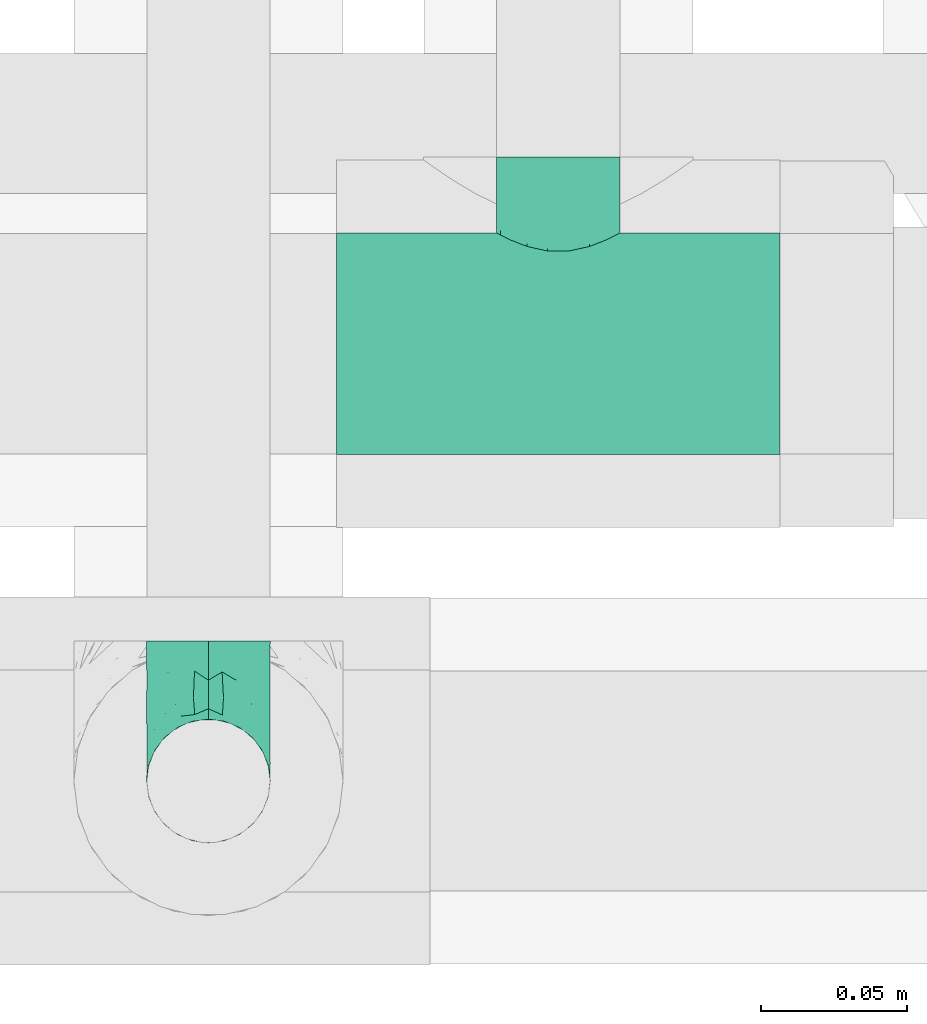
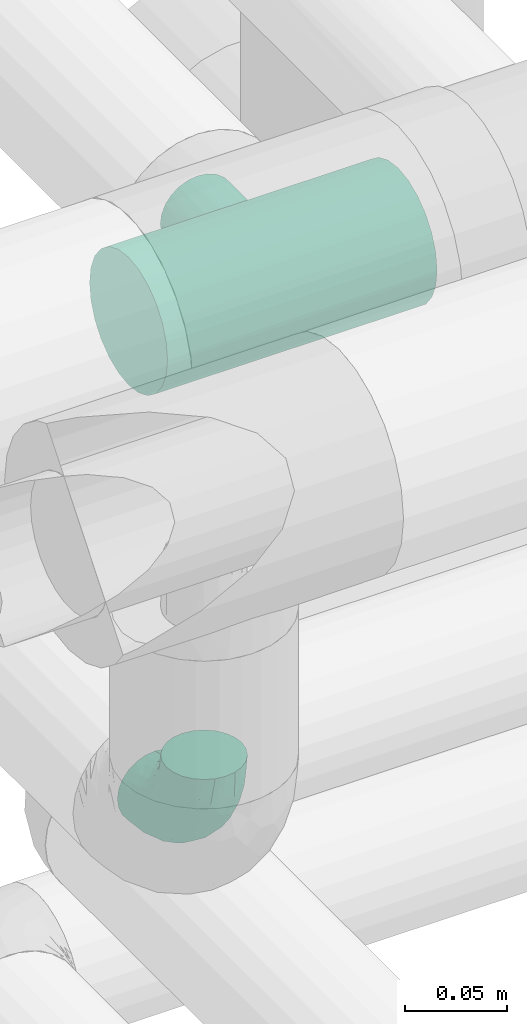
# One storey, part 691 of 827: 2 flow fittings.
"""IFC2X3 building model written with IfcOpenShell, lengths in millimetres."""

import ifcopenshell
import ifcopenshell.guid

model = None  # the IFC model being written
_history = None  # IfcOwnerHistory: only IFC2X3 demands one
_inside = {}  # id of a spatial element -> (the spatial element, [elements in it])
_under = {}  # id of a project, library or spatial element -> (it, [spatial elements below it])
_declared = {}  # id of a project -> (the project, [libraries it declares])
_typed = {}  # id of a type object -> (the type object, [elements of that type])
_made_of = {}  # id of a material, layer set ... -> (it, [elements and type objects made of it])


def new_model(schema):
    """Start an empty IFC model of exactly this schema.

    Asked for "IFC4X3", IfcOpenShell would pick the latest addendum, in which some entities
    have other attributes; the version numbers below select the first issue.
    IFC2X3 requires an IfcOwnerHistory on every rooted entity: one is made here for all.
    """
    global model, _history
    if schema == "IFC4X3":
        model = ifcopenshell.file(schema_version=(4, 3, 0, 0))
    else:
        model = ifcopenshell.file(schema=schema)
    _inside.clear()
    _under.clear()
    _declared.clear()
    _typed.clear()
    _made_of.clear()
    _history = None
    if model.schema == "IFC2X3":
        org = make("IfcOrganization", Name="unknown")
        user = make(
            "IfcPersonAndOrganization",
            ThePerson=make("IfcPerson", FamilyName="unknown"),
            TheOrganization=org,
        )
        app = make(
            "IfcApplication",
            ApplicationDeveloper=org,
            Version="unknown",
            ApplicationFullName="unknown",
            ApplicationIdentifier="unknown",
        )
        _history = make(
            "IfcOwnerHistory",
            OwningUser=user,
            OwningApplication=app,
            ChangeAction="ADDED",
            CreationDate=0,
        )
    return model


def make(cls, **values):
    """One entity of the class cls with the attributes given. An attribute that is None is left unset."""
    return model.create_entity(
        cls, **{name: value for name, value in values.items() if value is not None}
    )


def entity(cls, *values):
    """Any entity or typed value of the class cls, its attributes in the order of the schema. None: left unset."""
    e = model.create_entity(cls)
    for i, value in enumerate(values):
        if value is not None:
            e[i] = value
    return e


def rooted(cls, **values):
    """An entity with a GlobalId (a new one), such as an element, a storey or a relation."""
    return make(cls, GlobalId=ifcopenshell.guid.new(), OwnerHistory=_history, **values)


def si_unit(unit_type, name, prefix=None):
    """IfcSIUnit, for example si_unit("LENGTHUNIT", "METRE", prefix="MILLI")."""
    return make("IfcSIUnit", UnitType=unit_type, Prefix=prefix, Name=name)


def converted_unit(unit_type, name, factor, base, dimensions=None, offset=None):
    """IfcConversionBasedUnit, such as the inch: factor (a typed value) times the base unit."""
    return make(
        "IfcConversionBasedUnit"
        if offset is None
        else "IfcConversionBasedUnitWithOffset",
        ConversionOffset=offset,
        Dimensions=None
        if dimensions is None
        else entity("IfcDimensionalExponents", *dimensions),
        UnitType=unit_type,
        Name=name,
        ConversionFactor=make(
            "IfcMeasureWithUnit", ValueComponent=factor, UnitComponent=base
        ),
    )


def derived_unit(unit_type, elements):
    """IfcDerivedUnit: a product of units, each with its exponent."""
    return make(
        "IfcDerivedUnit",
        Elements=[
            make("IfcDerivedUnitElement", Unit=unit, Exponent=power)
            for unit, power in elements
        ],
        UnitType=unit_type,
    )


def assignment(units):
    """IfcUnitAssignment: the units of a project."""
    return None if units is None else make("IfcUnitAssignment", Units=units)


def point(xyz):
    """IfcCartesianPoint."""
    return None if xyz is None else make("IfcCartesianPoint", Coordinates=xyz)


def direction(xyz):
    """IfcDirection."""
    return None if xyz is None else make("IfcDirection", DirectionRatios=xyz)


def frame(location, z_axis=None, x_axis=None):
    """IfcAxis2Placement3D, a coordinate frame: its origin and axes. An axis left out is left unset."""
    return make(
        "IfcAxis2Placement3D",
        Location=point(location),
        Axis=direction(z_axis),
        RefDirection=direction(x_axis),
    )


def origin():
    """The frame at (0, 0, 0) with its axes left unset."""
    return frame((0.0, 0.0, 0.0))


def place(relative_to, where):
    """IfcLocalPlacement: puts the frame where relative to a parent placement (None: the world)."""
    return make(
        "IfcLocalPlacement", PlacementRelTo=relative_to, RelativePlacement=where
    )


def context(
    kind, dimensions, precision=None, world=None, true_north=None, identifier=None
):
    """IfcGeometricRepresentationContext, for example the 3D "Model" context."""
    return make(
        "IfcGeometricRepresentationContext",
        ContextIdentifier=identifier,
        ContextType=kind,
        CoordinateSpaceDimension=dimensions,
        Precision=precision,
        WorldCoordinateSystem=world,
        TrueNorth=true_north,
    )


def subcontext(parent, identifier, kind, view, scale=None):
    """IfcGeometricRepresentationSubContext, for example "Body" below "Model"."""
    return make(
        "IfcGeometricRepresentationSubContext",
        ContextIdentifier=identifier,
        ContextType=kind,
        ParentContext=parent,
        TargetScale=scale,
        TargetView=view,
    )


def project(units=None, contexts=None):
    """IfcProject with its units and contexts."""
    return rooted(
        "IfcProject",
        Name="project",
        RepresentationContexts=contexts,
        UnitsInContext=assignment(units),
    )


def spatial(cls, under=None, at=None, **own):
    """A site, building, storey or space (cls), placed at a placement, below another one or the project."""
    s = rooted(cls, ObjectPlacement=at, **own)
    if under is not None:
        _under.setdefault(under.id(), (under, []))[1].append(s)
    return s


def faces_of(points, faces, orient=None, outer=None):
    """IfcFace entities. A face is a list of loops; a loop is a list of indices into points, from 0.

    orient and outer hold one flag for each loop. By default every Orientation is true, the
    first loop of a face is its IfcFaceOuterBound and the others are IfcFaceBound.
    """
    made = []
    for i, loops in enumerate(faces):
        bounds = []
        for j, loop in enumerate(loops):
            is_outer = j == 0 if outer is None else outer[i][j]
            bounds.append(
                make(
                    "IfcFaceOuterBound" if is_outer else "IfcFaceBound",
                    Bound=make("IfcPolyLoop", Polygon=[points[k] for k in loop]),
                    Orientation=True if orient is None else orient[i][j],
                )
            )
        made.append(make("IfcFace", Bounds=bounds))
    return made


def faceted_brep(points, faces, orient=None, outer=None, voids=None):
    """IfcFacetedBrep: a solid bounded by flat faces; with voids (closed shells), ...WithVoids."""
    shared = [point(p) for p in points]
    hull = make("IfcClosedShell", CfsFaces=faces_of(shared, faces, orient, outer))
    if voids is None:
        return make("IfcFacetedBrep", Outer=hull)
    return make(
        "IfcFacetedBrepWithVoids",
        Outer=hull,
        Voids=[
            make(cls, CfsFaces=faces_of(shared, fs, o, b)) for cls, fs, o, b in voids
        ],
    )


def shape(context_of_items, identifier, shape_type, items):
    """IfcShapeRepresentation: the items that make up one representation, for example the "Body"."""
    return make(
        "IfcShapeRepresentation",
        ContextOfItems=context_of_items,
        RepresentationIdentifier=identifier,
        RepresentationType=shape_type,
        Items=items,
    )


def source(mapping_origin, context_of_items, identifier, shape_type, items):
    """IfcRepresentationMap: a shape defined once, which mapped items show again and again."""
    return make(
        "IfcRepresentationMap",
        MappingOrigin=mapping_origin,
        MappedRepresentation=shape(context_of_items, identifier, shape_type, items),
    )


def transform(
    local_origin,
    x_axis=None,
    y_axis=None,
    z_axis=None,
    scale=None,
    scale2=None,
    scale3=None,
    uniform=True,
):
    """IfcCartesianTransformationOperator3D, or its non-uniform kind. x_axis, y_axis, z_axis: its Axis1, 2, 3."""
    if uniform:
        return make(
            "IfcCartesianTransformationOperator3D",
            Axis1=direction(x_axis),
            Axis2=direction(y_axis),
            LocalOrigin=point(local_origin),
            Scale=scale,
            Axis3=direction(z_axis),
        )
    return make(
        "IfcCartesianTransformationOperator3DnonUniform",
        Axis1=direction(x_axis),
        Axis2=direction(y_axis),
        LocalOrigin=point(local_origin),
        Scale=scale,
        Axis3=direction(z_axis),
        Scale2=scale2,
        Scale3=scale3,
    )


def mapped(mapping_source, mapping_target):
    """IfcMappedItem: shows the shape of a source again, moved by a transform."""
    return make(
        "IfcMappedItem", MappingSource=mapping_source, MappingTarget=mapping_target
    )


def material(Name=None, Category=None):
    """IfcMaterial."""
    return make("IfcMaterial", Name=Name, Category=Category)


def made_of(thing, what):
    """Note that an element or type object is made of a material, layer set ...; save() writes the relation."""
    if what is not None:
        _made_of.setdefault(what.id(), (what, []))[1].append(thing)
    return thing


def type_object(cls, material=None, **own):
    """A type object (cls), such as IfcWallType, which elements share."""
    return made_of(rooted(cls, **own), material)


def type_shapes(of_type, sources):
    """Give a type object the sources (RepresentationMaps) that its elements show as mapped items."""
    of_type.RepresentationMaps = sources


def element(
    cls,
    number,
    at=None,
    inside=None,
    cuts=None,
    type_object=None,
    material=None,
    context=None,
    identifier="Body",
    shape_type=None,
    held_by="IfcProductDefinitionShape",
    body=None,
    shapes=None,
    **own,
):
    """One element of the class cls, such as IfcWall. Its Tag is "e" and its number.

    at: its placement. inside: the storey or other place that contains it. cuts: it is an
    opening in that element (IfcRelVoidsElement). A single representation is given by context,
    identifier, shape_type and body (its items); several are given by shapes. held_by: the class
    of the entity that holds the representations. save() writes the other relations.
    """
    e = rooted(cls, Tag="e%d" % number, ObjectPlacement=at, **own)
    if body is not None:
        shapes = [shape(context, identifier, shape_type, body)]
    if shapes is not None:
        e.Representation = make(held_by, Representations=shapes)
    if inside is not None:
        _inside.setdefault(inside.id(), (inside, []))[1].append(e)
    if cuts is not None:
        rooted(
            "IfcRelVoidsElement", RelatingBuildingElement=cuts, RelatedOpeningElement=e
        )
    if type_object is not None:
        _typed.setdefault(type_object.id(), (type_object, []))[1].append(e)
    return made_of(e, material)


def aggregate(whole, parts):
    """IfcRelAggregates: a whole, such as a stair, and the parts it consists of."""
    return rooted("IfcRelAggregates", RelatingObject=whole, RelatedObjects=parts)


def save(model, path):
    """Write the relations noted so far, then the file.

    IfcRelAggregates (storeys below a building ...), IfcRelContainedInSpatialStructure (elements
    in a storey), IfcRelDefinesByType, IfcRelAssociatesMaterial and IfcRelDeclares: one each for
    every whole, place, type object, material and project.
    """
    for whole, parts in _under.values():
        aggregate(whole, parts)
    for where, things in _inside.values():
        rooted(
            "IfcRelContainedInSpatialStructure",
            RelatedElements=things,
            RelatingStructure=where,
        )
    for kind, things in _typed.values():
        rooted("IfcRelDefinesByType", RelatedObjects=things, RelatingType=kind)
    for what, things in _made_of.values():
        rooted("IfcRelAssociatesMaterial", RelatedObjects=things, RelatingMaterial=what)
    for by, libraries in _declared.values():
        rooted("IfcRelDeclares", RelatingContext=by, RelatedDefinitions=libraries)
    model.write(path)


model = new_model("IFC2X3")

# Units and contexts
model_context = context("Model", 3, precision=0.01, world=origin(), true_north=direction((6.12303176911189e-17, 1.0)))
body_context = subcontext(model_context, "Body", "Model", "MODEL_VIEW")
ifc_project = project(units=[si_unit("LENGTHUNIT", "METRE", prefix="MILLI"), si_unit("AREAUNIT", "SQUARE_METRE"), si_unit("VOLUMEUNIT", "CUBIC_METRE"), converted_unit("PLANEANGLEUNIT", "DEGREE", entity("IfcRatioMeasure", 0.0174532925199433), si_unit("PLANEANGLEUNIT", "RADIAN"), dimensions=[0, 0, 0, 0, 0, 0, 0]), si_unit("MASSUNIT", "GRAM", prefix="KILO"), derived_unit("MASSDENSITYUNIT", [(si_unit("MASSUNIT", "GRAM", prefix="KILO"), 1), (si_unit("LENGTHUNIT", "METRE"), -3)]), derived_unit("MOMENTOFINERTIAUNIT", [(si_unit("LENGTHUNIT", "METRE"), 4)]), si_unit("TIMEUNIT", "SECOND"), si_unit("FREQUENCYUNIT", "HERTZ"), si_unit("THERMODYNAMICTEMPERATUREUNIT", "DEGREE_CELSIUS"), derived_unit("THERMALTRANSMITTANCEUNIT", [(si_unit("MASSUNIT", "GRAM", prefix="KILO"), 1), (si_unit("THERMODYNAMICTEMPERATUREUNIT", "KELVIN"), -1), (si_unit("TIMEUNIT", "SECOND"), -3)]), derived_unit("VOLUMETRICFLOWRATEUNIT", [(si_unit("LENGTHUNIT", "METRE"), 3), (si_unit("TIMEUNIT", "SECOND"), -1)]), derived_unit("MASSFLOWRATEUNIT", [(si_unit("MASSUNIT", "GRAM", prefix="KILO"), 1), (si_unit("TIMEUNIT", "SECOND"), -1)]), derived_unit("ROTATIONALFREQUENCYUNIT", [(si_unit("TIMEUNIT", "SECOND"), -1)]), si_unit("ELECTRICCURRENTUNIT", "AMPERE"), si_unit("ELECTRICVOLTAGEUNIT", "VOLT"), si_unit("POWERUNIT", "WATT"), si_unit("FORCEUNIT", "NEWTON", prefix="KILO"), si_unit("ILLUMINANCEUNIT", "LUX"), si_unit("LUMINOUSFLUXUNIT", "LUMEN"), si_unit("LUMINOUSINTENSITYUNIT", "CANDELA"), derived_unit("USERDEFINED", [(si_unit("MASSUNIT", "GRAM", prefix="KILO"), -1), (si_unit("LENGTHUNIT", "METRE"), -2), (si_unit("TIMEUNIT", "SECOND"), 3), (si_unit("LUMINOUSFLUXUNIT", "LUMEN"), 1)]), derived_unit("LINEARVELOCITYUNIT", [(si_unit("LENGTHUNIT", "METRE"), 1), (si_unit("TIMEUNIT", "SECOND"), -1)]), si_unit("PRESSUREUNIT", "PASCAL"), derived_unit("USERDEFINED", [(si_unit("LENGTHUNIT", "METRE"), -2), (si_unit("MASSUNIT", "GRAM", prefix="KILO"), 1), (si_unit("TIMEUNIT", "SECOND"), -2)]), derived_unit("LINEARFORCEUNIT", [(si_unit("MASSUNIT", "GRAM", prefix="KILO"), 1), (si_unit("LENGTHUNIT", "METRE"), 1), (si_unit("TIMEUNIT", "SECOND"), -2), (si_unit("LENGTHUNIT", "METRE"), -1)]), derived_unit("PLANARFORCEUNIT", [(si_unit("MASSUNIT", "GRAM", prefix="KILO"), 1), (si_unit("LENGTHUNIT", "METRE"), 1), (si_unit("TIMEUNIT", "SECOND"), -2), (si_unit("LENGTHUNIT", "METRE"), -2)])], contexts=[model_context])

# Site, building, storey
site_placement = place(None, origin())
site = spatial("IfcSite", under=ifc_project, at=site_placement, CompositionType="ELEMENT")
building_placement = place(site_placement, origin())
building = spatial("IfcBuilding", under=site, at=building_placement, CompositionType="ELEMENT")
storey_placement = place(building_placement, frame((0.0, 0.0, 28200.0)))
storey = spatial("IfcBuildingStorey", under=building, at=storey_placement, Name="08", CompositionType="ELEMENT", Elevation=28200.0)

# Flow fittings
ifc_material = material()
pipe_fitting_type_1 = type_object("IfcPipeFittingType", Name="ADSK_1", PredefinedType="NOTDEFINED", material=ifc_material)
shared_shape_1 = source(origin(), body_context, "Body", "Brep", [
    faceted_brep([(-48.0, 10.6, -18.36), (-48.0, 5.49, -20.48), (-48.0, 0.0, -21.2), (-48.0, -5.49, -20.48), (-48.0, -10.6, -18.36), (-48.0, -14.99, -14.99), (-48.0, -18.36, -10.6), (-48.0, -20.48, -5.49), (-48.0, -21.2, 0.0), (-48.0, -20.48, 5.49), (-48.0, -18.36, 10.6), (-48.0, -14.99, 14.99), (-48.0, -10.6, 18.36), (-48.0, -5.49, 20.48), (-48.0, 0.0, 21.2), (-48.0, 5.49, 20.48), (-48.0, 10.6, 18.36), (-48.0, 14.99, 14.99), (-48.0, 18.36, 10.6), (-48.0, 20.48, 5.49), (-48.0, 21.2, 0.0), (-48.0, 20.48, -5.49), (-48.0, 18.36, -10.6), (-48.0, 14.99, -14.99), (0.0, 48.0, -21.2), (-5.49, 48.0, -20.48), (-10.6, 48.0, -18.36), (-14.99, 48.0, -14.99), (-18.36, 48.0, -10.6), (-20.48, 48.0, -5.49), (-21.2, 48.0, 0.0), (-20.48, 48.0, 5.49), (-18.36, 48.0, 10.6), (-14.99, 48.0, 14.99), (-10.6, 48.0, 18.36), (-5.49, 48.0, 20.48), (0.0, 48.0, 21.2), (5.49, 48.0, 20.48), (10.6, 48.0, 18.36), (14.99, 48.0, 14.99), (18.36, 48.0, 10.6), (20.48, 48.0, 5.49), (21.2, 48.0, 0.0), (20.48, 48.0, -5.49), (18.36, 48.0, -10.6), (14.99, 48.0, -14.99), (10.6, 48.0, -18.36), (5.49, 48.0, -20.48), (-35.25, -16.22, 12.01), (-34.76, -18.57, 0.0), (-20.87, -12.37, 10.9), (-31.49, -11.78, 15.9), (-37.0, -2.58, 20.86), (-33.89, 3.62, 21.15), (-31.81, -18.14, 6.76), (-5.78, 5.78, 17.67), (-19.42, -4.1, 17.86), (-9.6, -3.39, 13.73), (-35.44, -7.73, 19.13), (11.78, 31.49, 15.9), (-5.93, -5.46, 6.95), (-18.45, -13.78, 5.46), (-10.29, -8.43, 0.0), (-24.6, 0.55, 20.62), (-37.28, 17.94, 13.81), (-33.38, 22.85, 9.59), (-41.46, 20.06, 8.75), (-29.51, 20.45, 15.16), (-15.04, 10.79, 21.13), (-7.08, 16.98, 20.93), (-8.39, 23.51, 21.15), (-40.86, 13.03, 17.26), (-8.05, 41.26, 19.83), (-3.21, 35.97, 21.14), (8.53, 19.66, 14.74), (4.1, 19.42, 17.86), (-37.72, 22.66, 4.78), (-37.07, 8.58, 19.98), (-13.0, 5.43, 19.97), (-3.78, 13.93, 19.7), (3.02, 8.69, 13.43), (-2.27, -0.05, 10.65), (6.22, 6.99, 7.09), (-22.25, 34.6, 9.45), (18.14, 31.81, 6.76), (16.22, 35.25, 12.01), (12.37, 20.87, 10.9), (7.73, 35.44, 19.13), (-21.52, -15.93, 0.0), (2.58, 37.0, 20.86), (18.57, 34.76, 0.0), (13.78, 18.45, 5.46), (15.93, 21.52, 0.0), (-20.03, -8.54, 14.9), (-28.6, 28.6, 5.16), (-24.79, 34.6, 0.0), (-34.6, 24.79, 0.0), (-22.81, 37.41, 4.68), (-23.36, 26.33, 14.79), (-13.68, 37.05, 17.49), (-17.72, 38.12, 13.73), (-26.25, 27.3, 11.24), (-9.71, 32.34, 20.14), (-17.26, 25.6, 18.71), (-26.33, 9.99, 20.77), (-24.06, 6.05, 21.2), (-25.02, 15.46, 19.56), (-24.3, 20.72, 17.57), (-31.95, 15.23, 17.8), (-13.53, 24.7, 20.21), (-17.6, 17.6, 20.6), (-0.55, 24.6, 20.62), (-11.41, -7.48, 10.43), (0.93, -0.93, 0.0), (8.43, 10.29, 0.0), (-11.41, -7.48, -10.43), (-20.1, -8.84, -14.66), (-9.6, -3.39, -13.73), (7.73, 35.44, -19.13), (4.1, 19.42, -17.86), (-0.55, 24.6, -20.62), (-38.12, 17.72, -13.73), (-37.05, 13.68, -17.49), (-32.34, 9.71, -20.14), (-41.26, 8.05, -19.83), (-37.41, 22.81, -4.68), (-23.51, 8.39, -21.15), (-35.97, 3.21, -21.14), (-28.6, 28.6, -5.16), (-31.81, -18.14, -6.76), (-18.45, -13.78, -5.46), (-25.6, 17.26, -18.71), (-19.42, -4.1, -17.86), (-17.94, 37.28, -13.81), (-22.85, 33.38, -9.59), (-20.06, 41.46, -8.75), (-31.49, -11.78, -15.9), (-35.25, -16.22, -12.01), (8.53, 19.66, -14.74), (11.78, 31.49, -15.9), (-9.99, 26.33, -20.77), (-6.05, 24.06, -21.2), (-10.79, 15.04, -21.13), (-37.0, -2.58, -20.86), (-16.98, 7.08, -20.93), (-5.43, 13.0, -19.97), (-13.93, 3.78, -19.7), (-20.87, -12.37, -10.9), (-26.33, 23.36, -14.79), (-22.66, 37.72, -4.78), (13.78, 18.45, -5.46), (18.14, 31.81, -6.76), (-15.46, 25.02, -19.56), (-20.72, 24.3, -17.57), (16.22, 35.25, -12.01), (-13.03, 40.86, -17.26), (-8.58, 37.07, -19.98), (2.58, 37.0, -20.86), (-3.62, 33.89, -21.15), (-34.6, 22.25, -9.45), (6.22, 6.99, -7.09), (-20.45, 29.51, -15.16), (-35.44, -7.73, -19.13), (12.37, 20.87, -10.9), (-27.3, 26.25, -11.24), (-15.23, 31.95, -17.8), (-24.7, 13.53, -20.21), (-24.6, 0.55, -20.62), (-5.78, 5.78, -17.67), (-17.6, 17.6, -20.6), (3.02, 8.69, -13.43), (-5.93, -5.46, -6.95), (-2.27, -0.05, -10.65)], [[[0, 1, 2, 3, 4, 5, 6, 7, 8, 9, 10, 11, 12, 13, 14, 15, 16, 17, 18, 19, 20, 21, 22, 23]], [[24, 25, 26, 27, 28, 29, 30, 31, 32, 33, 34, 35, 36, 37, 38, 39, 40, 41, 42, 43, 44, 45, 46, 47]], [[10, 48, 11]], [[9, 8, 49]], [[48, 50, 51]], [[14, 52, 53]], [[10, 54, 48]], [[9, 54, 10]], [[55, 56, 57]], [[51, 12, 11]], [[51, 58, 12]], [[59, 39, 38]], [[60, 61, 62]], [[58, 56, 63]], [[64, 65, 66]], [[67, 65, 64]], [[68, 69, 70]], [[16, 71, 17]], [[13, 52, 14]], [[35, 72, 73]], [[14, 53, 15]], [[17, 64, 18]], [[74, 59, 75]], [[20, 19, 76]], [[66, 19, 18]], [[77, 15, 53]], [[15, 77, 16]], [[69, 78, 79]], [[80, 81, 82]], [[32, 31, 83]], [[84, 85, 86]], [[59, 87, 75]], [[61, 54, 88]], [[36, 89, 37]], [[84, 41, 40]], [[36, 35, 73]], [[90, 41, 84]], [[40, 39, 85]], [[12, 58, 13]], [[85, 84, 40]], [[91, 84, 86]], [[84, 92, 90]], [[87, 38, 37]], [[93, 56, 51]], [[65, 94, 76]], [[94, 95, 96]], [[84, 91, 92]], [[95, 97, 30]], [[98, 99, 100]], [[76, 94, 96]], [[101, 98, 83]], [[100, 99, 33]], [[102, 70, 73]], [[103, 102, 99]], [[94, 97, 95]], [[72, 99, 102]], [[72, 35, 34]], [[34, 33, 99]], [[9, 49, 54]], [[87, 59, 38]], [[104, 105, 68]], [[106, 103, 107]], [[106, 77, 104]], [[71, 64, 17]], [[108, 107, 67]], [[33, 32, 100]], [[109, 103, 110]], [[102, 109, 70]], [[89, 73, 111]], [[50, 48, 54]], [[51, 11, 48]], [[56, 58, 51]], [[88, 54, 49]], [[52, 58, 63]], [[50, 112, 93]], [[56, 55, 78]], [[39, 59, 85]], [[86, 85, 59]], [[89, 87, 37]], [[42, 41, 90]], [[111, 79, 75]], [[111, 75, 87]], [[75, 55, 80]], [[104, 77, 53]], [[71, 77, 108]], [[32, 83, 100]], [[98, 100, 83]], [[99, 98, 103]], [[106, 107, 108]], [[68, 70, 110]], [[111, 73, 70]], [[68, 110, 104]], [[68, 63, 78]], [[57, 93, 112]], [[80, 55, 57]], [[61, 50, 54]], [[80, 82, 86]], [[81, 57, 112]], [[74, 86, 59]], [[60, 113, 82]], [[82, 114, 91]], [[101, 94, 65]], [[97, 94, 83]], [[73, 89, 36]], [[87, 89, 111]], [[58, 52, 13]], [[53, 52, 63]], [[104, 53, 105]], [[106, 104, 110]], [[20, 76, 96]], [[76, 19, 66]], [[103, 106, 110]], [[77, 106, 108]], [[103, 98, 107]], [[67, 107, 98]], [[67, 98, 101]], [[108, 67, 64]], [[53, 63, 105]], [[63, 68, 105]], [[83, 31, 97]], [[30, 97, 31]], [[62, 113, 60]], [[112, 61, 60]], [[61, 88, 62]], [[86, 82, 91]], [[56, 78, 63]], [[114, 82, 113]], [[114, 92, 91]], [[79, 78, 55]], [[75, 79, 55]], [[69, 79, 111]], [[70, 69, 111]], [[78, 69, 68]], [[77, 71, 16]], [[64, 71, 108]], [[64, 66, 18]], [[76, 66, 65]], [[99, 72, 34]], [[73, 72, 102]], [[94, 101, 83]], [[67, 101, 65]], [[75, 80, 74]], [[80, 86, 74]], [[70, 109, 110]], [[102, 103, 109]], [[50, 93, 51]], [[57, 56, 93]], [[61, 112, 50]], [[81, 112, 60]], [[82, 81, 60]], [[80, 57, 81]], [[115, 116, 117]], [[118, 119, 120]], [[121, 122, 23]], [[123, 124, 122]], [[96, 125, 20]], [[123, 126, 127]], [[128, 96, 95]], [[129, 130, 88]], [[123, 122, 131]], [[116, 132, 117]], [[133, 134, 135]], [[0, 124, 1]], [[5, 136, 137]], [[138, 119, 139]], [[129, 88, 49]], [[140, 141, 142]], [[6, 5, 137]], [[46, 118, 47]], [[143, 3, 2]], [[144, 145, 146]], [[6, 129, 7]], [[129, 137, 147]], [[127, 2, 1]], [[148, 122, 121]], [[128, 125, 96]], [[134, 128, 149]], [[95, 149, 128]], [[150, 151, 92]], [[30, 29, 149]], [[152, 131, 153]], [[27, 133, 28]], [[154, 45, 44]], [[136, 5, 4]], [[27, 26, 155]], [[156, 26, 25]], [[24, 157, 158]], [[24, 47, 157]], [[22, 21, 159]], [[160, 150, 114]], [[134, 133, 161]], [[142, 144, 126]], [[46, 139, 118]], [[162, 136, 4]], [[156, 25, 158]], [[1, 124, 127]], [[115, 147, 116]], [[45, 154, 139]], [[139, 46, 45]], [[154, 163, 139]], [[162, 4, 3]], [[42, 90, 43]], [[130, 129, 147]], [[49, 7, 129]], [[43, 151, 44]], [[0, 23, 122]], [[24, 158, 25]], [[136, 162, 132]], [[135, 29, 28]], [[43, 90, 151]], [[164, 148, 159]], [[152, 156, 140]], [[155, 133, 27]], [[165, 153, 161]], [[23, 22, 121]], [[123, 131, 166]], [[123, 166, 126]], [[143, 127, 167]], [[147, 137, 136]], [[8, 7, 49]], [[129, 6, 137]], [[143, 162, 3]], [[167, 146, 132]], [[167, 132, 162]], [[132, 168, 117]], [[44, 151, 154]], [[92, 151, 90]], [[163, 154, 151]], [[119, 118, 139]], [[157, 118, 120]], [[138, 139, 163]], [[119, 168, 145]], [[140, 156, 158]], [[155, 156, 165]], [[22, 159, 121]], [[148, 121, 159]], [[122, 148, 131]], [[152, 153, 165]], [[142, 126, 169]], [[167, 127, 126]], [[142, 169, 140]], [[142, 120, 145]], [[168, 170, 117]], [[160, 171, 172]], [[115, 172, 171]], [[171, 62, 130]], [[119, 170, 168]], [[170, 163, 160]], [[150, 163, 151]], [[113, 171, 160]], [[164, 128, 134]], [[125, 128, 159]], [[127, 143, 2]], [[162, 143, 167]], [[118, 157, 47]], [[158, 157, 120]], [[140, 158, 141]], [[152, 140, 169]], [[30, 149, 95]], [[149, 29, 135]], [[131, 152, 169]], [[156, 152, 165]], [[131, 148, 153]], [[161, 153, 148]], [[161, 148, 164]], [[165, 161, 133]], [[158, 120, 141]], [[120, 142, 141]], [[159, 21, 125]], [[20, 125, 21]], [[115, 130, 147]], [[114, 113, 160]], [[62, 171, 113]], [[62, 88, 130]], [[160, 163, 150]], [[150, 92, 114]], [[119, 145, 120]], [[146, 145, 168]], [[132, 146, 168]], [[144, 146, 167]], [[126, 144, 167]], [[145, 144, 142]], [[156, 155, 26]], [[133, 155, 165]], [[133, 135, 28]], [[149, 135, 134]], [[122, 124, 0]], [[127, 124, 123]], [[128, 164, 159]], [[161, 164, 134]], [[163, 170, 138]], [[170, 119, 138]], [[131, 169, 166]], [[126, 166, 169]], [[147, 136, 116]], [[132, 116, 136]], [[172, 115, 117]], [[130, 115, 171]], [[117, 170, 172]], [[160, 172, 170]]]),
])
type_shapes(pipe_fitting_type_1, [shared_shape_1])
flow_fitting_1_placement = place(storey_placement, frame((54069.79, 15922.38, 2500.0), z_axis=(1.0, 0.0, 0.0), x_axis=(0.0, 0.0, -1.0)))
element("IfcFlowFitting", 1, at=flow_fitting_1_placement, inside=storey, type_object=pipe_fitting_type_1, material=ifc_material, Name="ADSK_1", ObjectType="ADSK_1", context=body_context, shape_type="MappedRepresentation", body=[
    mapped(shared_shape_1, transform((0.0, 0.0, 0.0), scale=1.0)),
])
pipe_fitting_type_2 = type_object("IfcPipeFittingType", Name="ADSK_1", PredefinedType="NOTDEFINED", material=ifc_material)
shared_shape_2 = source(origin(), body_context, "Body", "Brep", [
    faceted_brep([(-76.0, 9.85, -36.75), (-76.0, 0.0, -38.05), (-76.0, -9.85, -36.75), (-76.0, -19.03, -32.95), (-76.0, -26.91, -26.91), (-76.0, -32.95, -19.03), (-76.0, -36.75, -9.85), (-76.0, -38.05, 0.0), (-76.0, -36.75, 9.85), (-76.0, -32.95, 19.02), (-76.0, -26.91, 26.91), (-76.0, -19.03, 32.95), (-76.0, -9.85, 36.75), (-76.0, 0.0, 38.05), (-76.0, 9.85, 36.75), (-76.0, 19.02, 32.95), (-76.0, 26.91, 26.91), (-76.0, 32.95, 19.02), (-76.0, 36.75, 9.85), (-76.0, 38.05, 0.0), (-76.0, 36.75, -9.85), (-76.0, 32.95, -19.03), (-76.0, 26.91, -26.91), (-76.0, 19.02, -32.95), (76.0, 26.91, -26.91), (76.0, 32.95, -19.03), (76.0, 36.75, -9.85), (76.0, 38.05, 0.0), (76.0, 36.75, 9.85), (76.0, 32.95, 19.02), (76.0, 26.91, 26.91), (76.0, 19.02, 32.95), (76.0, 9.85, 36.75), (76.0, 0.0, 38.05), (76.0, -9.85, 36.75), (76.0, -19.03, 32.95), (76.0, -26.91, 26.91), (76.0, -32.95, 19.02), (76.0, -36.75, 9.85), (76.0, -38.05, 0.0), (76.0, -36.75, -9.85), (76.0, -32.95, -19.03), (76.0, -26.91, -26.91), (76.0, -19.03, -32.95), (76.0, -9.85, -36.75), (76.0, 0.0, -38.05), (76.0, 9.85, -36.75), (76.0, 19.02, -32.95), (19.88, -37.33, 7.37), (20.54, -37.69, 3.68), (21.2, -38.05, 0.0), (16.2, -35.51, 13.68), (3.75, -31.82, 20.87), (10.67, -33.35, 18.32), (7.21, -32.58, 19.59), (-21.2, -38.05, 0.0), (-20.54, -37.69, 3.68), (-19.88, -37.33, 7.37), (-16.2, -35.51, 13.67), (-10.67, -33.35, 18.32), (-7.22, -32.59, 19.59), (-3.76, -31.82, 20.86), (0.0, -31.82, 20.86), (3.75, -31.82, -20.87), (10.67, -33.35, -18.32), (7.21, -32.58, -19.59), (16.2, -35.51, -13.68), (19.88, -37.33, -7.37), (20.54, -37.69, -3.68), (-3.76, -31.82, -20.86), (-7.22, -32.59, -19.59), (-10.67, -33.35, -18.32), (-16.2, -35.51, -13.67), (0.0, -31.82, -20.86), (-19.88, -37.33, -7.37), (-20.54, -37.69, -3.68), (0.0, -64.0, -21.2), (5.49, -64.0, -20.48), (10.6, -64.0, -18.36), (14.99, -64.0, -14.99), (18.36, -64.0, -10.6), (20.48, -64.0, -5.49), (21.2, -64.0, 0.0), (20.48, -64.0, 5.49), (18.36, -64.0, 10.6), (14.99, -64.0, 14.99), (10.6, -64.0, 18.36), (5.49, -64.0, 20.48), (0.0, -64.0, 21.2), (-5.49, -64.0, 20.48), (-10.6, -64.0, 18.36), (-14.99, -64.0, 14.99), (-18.36, -64.0, 10.6), (-20.48, -64.0, 5.49), (-21.2, -64.0, 0.0), (-20.48, -64.0, -5.49), (-18.36, -64.0, -10.6), (-14.99, -64.0, -14.99), (-10.6, -64.0, -18.36), (-5.49, -64.0, -20.48)], [[[0, 1, 2, 3, 4, 5, 6, 7, 8, 9, 10, 11, 12, 13, 14, 15, 16, 17, 18, 19, 20, 21, 22, 23]], [[24, 25, 26, 27, 28, 29, 30, 31, 32, 33, 34, 35, 36, 37, 38, 39, 40, 41, 42, 43, 44, 45, 46, 47]], [[39, 38, 48]], [[39, 48, 49, 50]], [[38, 51, 48]], [[37, 36, 52]], [[53, 51, 37]], [[37, 52, 54, 53]], [[36, 10, 52]], [[37, 51, 38]], [[7, 55, 56, 57]], [[8, 7, 57]], [[57, 58, 8]], [[9, 59, 60, 61]], [[59, 9, 58]], [[9, 61, 10]], [[58, 9, 8]], [[10, 61, 62, 52]], [[36, 35, 11, 10]], [[13, 12, 34, 33]], [[12, 11, 35, 34]], [[14, 13, 33, 32]], [[29, 28, 18, 17]], [[16, 15, 31, 30]], [[17, 16, 30, 29]], [[32, 31, 15, 14]], [[19, 18, 28, 27]], [[26, 25, 21, 20]], [[25, 24, 22, 21]], [[27, 26, 20, 19]], [[45, 44, 2, 1]], [[0, 23, 47, 46]], [[1, 0, 46, 45]], [[24, 47, 23, 22]], [[3, 2, 44, 43]], [[43, 42, 4, 3]], [[42, 41, 63]], [[41, 64, 65, 63]], [[41, 66, 64]], [[42, 63, 4]], [[40, 39, 67]], [[67, 66, 40]], [[39, 50, 68, 67]], [[40, 66, 41]], [[5, 69, 70, 71]], [[5, 4, 69]], [[71, 72, 5]], [[4, 63, 73, 69]], [[72, 74, 6]], [[74, 7, 6]], [[7, 74, 75, 55]], [[72, 6, 5]], [[76, 77, 78, 79, 80, 81, 82, 83, 84, 85, 86, 87, 88, 89, 90, 91, 92, 93, 94, 95, 96, 97, 98, 99]], [[93, 56, 94]], [[88, 61, 89]], [[60, 90, 89]], [[60, 59, 90]], [[93, 57, 56]], [[57, 93, 92]], [[49, 48, 83]], [[58, 92, 91]], [[56, 55, 94]], [[57, 92, 58]], [[86, 54, 87]], [[59, 58, 91]], [[89, 61, 60]], [[59, 91, 90]], [[88, 52, 62, 61]], [[86, 53, 54]], [[85, 53, 86]], [[48, 84, 83]], [[85, 84, 51]], [[52, 88, 87]], [[54, 52, 87]], [[53, 85, 51]], [[51, 84, 48]], [[82, 49, 83]], [[49, 82, 50]], [[81, 68, 82]], [[66, 80, 79]], [[75, 94, 55]], [[81, 67, 68]], [[80, 67, 81]], [[78, 64, 79]], [[68, 50, 82]], [[67, 80, 66]], [[77, 63, 65]], [[64, 66, 79]], [[76, 69, 73, 63]], [[98, 70, 99]], [[65, 64, 78]], [[98, 71, 70]], [[76, 63, 77]], [[75, 74, 95]], [[97, 71, 98]], [[74, 96, 95]], [[97, 96, 72]], [[69, 76, 99]], [[70, 69, 99]], [[71, 97, 72]], [[72, 96, 74]], [[94, 75, 95]], [[65, 78, 77]]]),
])
type_shapes(pipe_fitting_type_2, [shared_shape_2])
flow_fitting_2_placement = place(storey_placement, frame((54189.79, 16072.38, 2700.0), z_axis=(0.0, 0.0, 1.0), x_axis=(-1.0, 0.0, 0.0)))
element("IfcFlowFitting", 2, at=flow_fitting_2_placement, inside=storey, type_object=pipe_fitting_type_2, material=ifc_material, Name="ADSK_1", ObjectType="ADSK_1", context=body_context, shape_type="MappedRepresentation", body=[
    mapped(shared_shape_2, transform((0.0, 0.0, 0.0), scale=1.0)),
])

save(model, "model.ifc")
